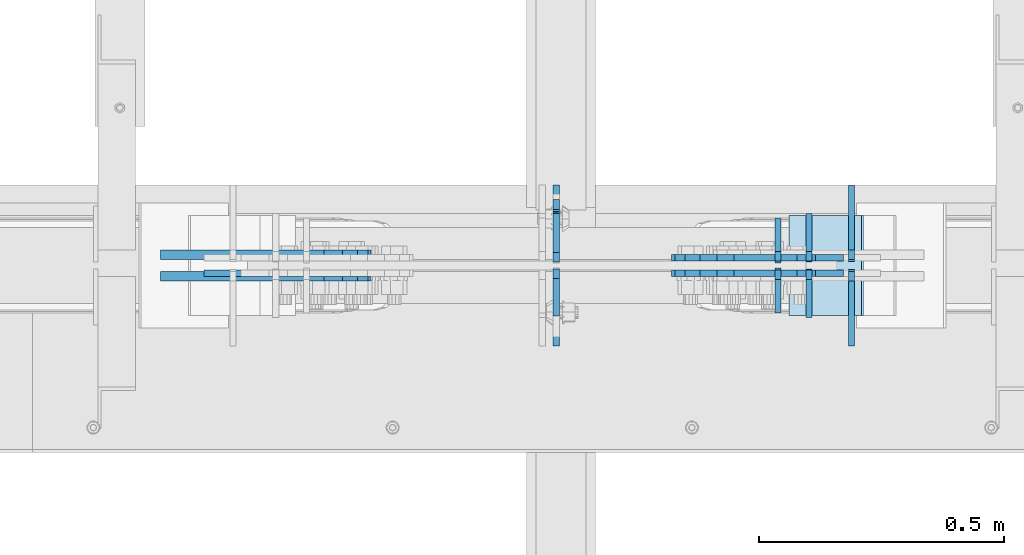
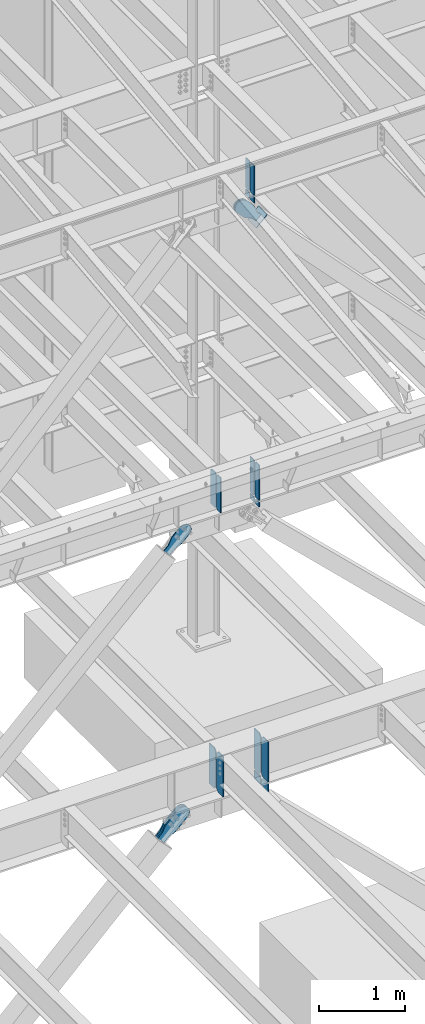
# One storey, part 1039 of 1179: 22 plates, 9 elements without a shape of their own.
"""IFC2X3 building model written with IfcOpenShell, lengths in millimetres."""

from ifc_helpers import new_model, si_unit, frame, origin_with_axes, place, context, subcontext, project, spatial, faceted_brep, material, type_object, element, aggregate, save


model = new_model("IFC2X3")

# Units and contexts
model_context = context("Model", 3, precision=1e-05, world=origin_with_axes())
body_context = subcontext(model_context, "Body", "Model", "MODEL_VIEW")
ifc_project = project(units=[si_unit("LENGTHUNIT", "METRE", prefix="MILLI"), si_unit("AREAUNIT", "SQUARE_METRE"), si_unit("VOLUMEUNIT", "CUBIC_METRE"), si_unit("MASSUNIT", "GRAM", prefix="KILO"), si_unit("TIMEUNIT", "SECOND"), si_unit("PLANEANGLEUNIT", "RADIAN"), si_unit("SOLIDANGLEUNIT", "STERADIAN"), si_unit("THERMODYNAMICTEMPERATUREUNIT", "DEGREE_CELSIUS"), si_unit("LUMINOUSINTENSITYUNIT", "LUMEN")], contexts=[model_context])

# Site, building, storey
site_placement = place(None, origin_with_axes())
site = spatial("IfcSite", under=ifc_project, at=site_placement, CompositionType="ELEMENT")
building_placement = place(site_placement, origin_with_axes())
building = spatial("IfcBuilding", under=site, at=building_placement, Name="Undefined", CompositionType="ELEMENT")
storey_placement = place(building_placement, origin_with_axes())
storey = spatial("IfcBuildingStorey", under=building, at=storey_placement, Name="Undefined", CompositionType="ELEMENT", Elevation=0.0)

# Assembly, plates
assembly_1_placement = place(storey_placement, origin_with_axes())
assembly_1 = element("IfcElementAssembly", 1, at=assembly_1_placement, inside=storey, Name="BEAM", AssemblyPlace="NOTDEFINED", PredefinedType="RIGID_FRAME")
ifc_material_1 = material(Name="STEEL/A572-GR.50")
plate_type_1 = type_object("IfcPlateType", PredefinedType="NOTDEFINED")
plate_1_placement = place(assembly_1_placement, frame((12398.375, 27043.85625, 7489.825), z_axis=(0.0, 0.0, 1.0), x_axis=(0.0, -1.0, 0.0)))
plate_1 = element("IfcPlate", 2, at=plate_1_placement, type_object=plate_type_1, material=ifc_material_1, Name="PLATE", context=body_context, shape_type="Brep", body=[
    faceted_brep([(0.0, -6.35000000000036, 19.0499999999993), (0.0, -6.350000000195, 479.425000761541), (0.0, 6.34999999980209, 479.425000761548), (0.0, 6.35000000000036, 19.0499999999993), (19.0499992370605, -6.35000000019863, 498.474999998592), (19.0499992370605, 6.34999999979118, 498.474999998596), (95.25, -6.349999999793, 498.474999998598), (95.25, 6.35000000020045, 498.474999998592), (95.25, -6.34999999999309, 1.81898940354586e-12), (95.25, 6.34999999999854, -1.81898940354586e-12), (19.0500000000002, -6.35000000000036, 0.0), (19.0500000000002, 6.35000000000036, 0.0)], [[[0, 1, 2, 3]], [[1, 4, 5, 2]], [[4, 6, 7, 5]], [[6, 8, 9, 7]], [[8, 10, 11, 9]], [[3, 11, 10, 0]], [[5, 7, 9, 11, 3, 2]], [[10, 8, 6, 4, 1, 0]]]),
])
plate_type_2 = type_object("IfcPlateType", PredefinedType="NOTDEFINED")
plate_2_placement = place(assembly_1_placement, frame((12912.8965081216, 27058.14375, 7489.825), z_axis=(0.0, 1.0, 0.0), x_axis=(0.0, 0.0, 1.0)))
plate_2 = element("IfcPlate", 3, at=plate_2_placement, type_object=plate_type_2, material=ifc_material_1, Name="PLATE", context=body_context, shape_type="Brep", body=[
    faceted_brep([(0.0, -6.34999999998763, 17.4624996185248), (0.0, -6.35000000000036, 99.21875), (0.0, 6.35000000000036, 99.21875), (0.0, 6.35000000000582, 17.4624996185175), (498.475, -6.35000000000036, 99.21875), (498.475, 6.35000000000036, 99.21875), (498.474999999775, -6.34999999979482, 17.4624996185303), (498.474999999769, 6.35000000019681, 17.4624996185303), (481.012500381255, -6.34999999980209, 0.0), (481.01250038125, 6.35000000019136, 0.0), (17.4624996185303, -6.34999999999309, 1.81898940354586e-12), (17.4624996185303, 6.34999999999854, -1.81898940354586e-12)], [[[0, 1, 2, 3]], [[1, 4, 5, 2]], [[4, 6, 7, 5]], [[6, 8, 9, 7]], [[8, 10, 11, 9]], [[10, 0, 3, 11]], [[5, 7, 9, 11, 3, 2]], [[10, 8, 6, 4, 1, 0]]]),
])
plate_3_placement = place(assembly_1_placement, frame((12912.8965081216, 27043.85625, 7489.825), z_axis=(0.0, -1.0, 0.0), x_axis=(0.0, 0.0, 1.0)))
plate_3 = element("IfcPlate", 4, at=plate_3_placement, type_object=plate_type_2, material=ifc_material_1, Name="PLATE", context=body_context, shape_type="Brep", body=[
    faceted_brep([(0.0, -6.34999999998763, 17.4624996185248), (0.0, -6.35000000000036, 99.21875), (0.0, 6.35000000000036, 99.21875), (0.0, 6.35000000000582, 17.4624996185175), (498.475, -6.35000000000036, 99.21875), (498.475, 6.35000000000036, 99.21875), (498.474999999775, -6.34999999979482, 17.4624996185303), (498.474999999769, 6.35000000019681, 17.4624996185303), (481.012500381255, -6.34999999980209, 0.0), (481.01250038125, 6.35000000019136, 0.0), (17.4624996185303, -6.34999999999309, 1.81898940354586e-12), (17.4624996185303, 6.34999999999854, -1.81898940354586e-12)], [[[0, 1, 2, 3]], [[1, 4, 5, 2]], [[4, 6, 7, 5]], [[6, 8, 9, 7]], [[8, 10, 11, 9]], [[10, 0, 3, 11]], [[5, 7, 9, 11, 3, 2]], [[10, 8, 6, 4, 1, 0]]]),
])

# Assembly, plate
assembly_2_placement = place(storey_placement, origin_with_axes())
assembly_2 = element("IfcElementAssembly", 5, at=assembly_2_placement, inside=storey, AssemblyPlace="NOTDEFINED", PredefinedType="RIGID_FRAME")
ifc_material_2 = material(Name="STEEL/A36")
plate_type_3 = type_object("IfcPlateType", PredefinedType="NOTDEFINED")
plate_4_placement = place(assembly_2_placement, frame((12926.5168524758, 27066.875, 11517.4881055865), z_axis=(-0.724386095169384, 0.0, -0.689394506161205), x_axis=(0.689394506161205, 0.0, -0.724386095169384)))
plate_4 = element("IfcPlate", 6, at=plate_4_placement, type_object=plate_type_3, material=ifc_material_2, context=body_context, shape_type="Brep", body=[
    faceted_brep([(0.0, -6.34999999999854, 0.0), (-101.600000000211, -6.34999999999854, -44.6881937825565), (-101.600000000211, 6.34999999999854, -44.6881937825565), (0.0, 6.34999999999854, 0.0), (-246.684985848258, -6.34999999999854, -44.6881937827675), (-246.684985848258, 6.34999999999854, -44.6881937827675), (-281.313054102191, -6.34999999999854, -37.800242748639), (-281.313054102191, 6.34999999999854, -37.800242748639), (-310.669312868691, -6.34999999999854, -18.1850177516608), (-310.669312868691, 6.34999999999854, -18.1850177516608), (-330.284537865713, -6.34999999999854, 11.1712410148393), (-330.284537865713, 6.34999999999854, 11.1712410148393), (-337.172488899912, -6.34999999999854, 45.7993031647638), (-337.172488899912, 6.34999999999854, 45.7993031647638), (-330.284537865768, -6.34999999999854, 80.4273714187839), (-330.284537865768, 6.34999999999854, 80.4273714187839), (-310.669312868773, -6.34999999999854, 109.783630185371), (-310.669312868773, 6.34999999999854, 109.783630185371), (-281.313054102271, -6.34999999999854, 129.398855182466), (-281.313054102271, 6.34999999999854, 129.398855182466), (-246.684988899762, -6.34999999999854, 136.286806216707), (-246.684988899762, 6.34999999999854, 136.286806216707), (-101.600000000377, -6.34999999999854, 136.286806216911), (-101.600000000377, 6.34999999999854, 136.286806216911), (-8.18545231595635e-11, -6.34999999999854, 91.5986124346418), (-8.18545231595635e-11, 6.34999999999854, 91.5986124346418), (82.5500000001266, -6.34999999999854, 91.5986124347546), (82.5500000001266, 6.34999999999854, 91.5986124347546), (82.550000000203, -6.34999999999854, 1.2732925824821e-10), (82.550000000203, 6.34999999999854, 1.2732925824821e-10)], [[[0, 1, 2, 3]], [[1, 4, 5, 2]], [[4, 6, 7, 5]], [[6, 8, 9, 7]], [[8, 10, 11, 9]], [[10, 12, 13, 11]], [[12, 14, 15, 13]], [[14, 16, 17, 15]], [[16, 18, 19, 17]], [[18, 20, 21, 19]], [[20, 22, 23, 21]], [[22, 24, 25, 23]], [[24, 26, 27, 25]], [[26, 28, 29, 27]], [[28, 0, 3, 29]], [[5, 7, 9, 11, 13, 15, 17, 19, 21, 23, 25, 27, 29, 3, 2]], [[28, 26, 24, 22, 20, 18, 16, 14, 12, 10, 8, 6, 4, 1, 0]]]),
])
aggregate(assembly_2, [plate_4])

assembly_3_placement = place(storey_placement, origin_with_axes())
assembly_3 = element("IfcElementAssembly", 7, at=assembly_3_placement, inside=storey, AssemblyPlace="NOTDEFINED", PredefinedType="RIGID_FRAME")
plate_5_placement = place(assembly_3_placement, frame((12926.5168524758, 27035.125, 11517.4881055865), z_axis=(-0.724386095169384, 0.0, -0.689394506161205), x_axis=(0.689394506161205, 0.0, -0.724386095169384)))
plate_5 = element("IfcPlate", 8, at=plate_5_placement, type_object=plate_type_3, material=ifc_material_2, context=body_context, shape_type="Brep", body=[
    faceted_brep([(0.0, -6.34999999999854, 0.0), (-101.600000000211, -6.34999999999854, -44.6881937825565), (-101.600000000211, 6.34999999999854, -44.6881937825565), (0.0, 6.34999999999854, 0.0), (-246.684985848258, -6.34999999999854, -44.6881937827675), (-246.684985848258, 6.34999999999854, -44.6881937827675), (-281.313054102191, -6.34999999999854, -37.800242748639), (-281.313054102191, 6.34999999999854, -37.800242748639), (-310.669312868691, -6.34999999999854, -18.1850177516608), (-310.669312868691, 6.34999999999854, -18.1850177516608), (-330.284537865713, -6.34999999999854, 11.1712410148393), (-330.284537865713, 6.34999999999854, 11.1712410148393), (-337.172488899912, -6.34999999999854, 45.7993031647638), (-337.172488899912, 6.34999999999854, 45.7993031647638), (-330.284537865768, -6.34999999999854, 80.4273714187839), (-330.284537865768, 6.34999999999854, 80.4273714187839), (-310.669312868773, -6.34999999999854, 109.783630185371), (-310.669312868773, 6.34999999999854, 109.783630185371), (-281.313054102271, -6.34999999999854, 129.398855182466), (-281.313054102271, 6.34999999999854, 129.398855182466), (-246.684988899762, -6.34999999999854, 136.286806216707), (-246.684988899762, 6.34999999999854, 136.286806216707), (-101.600000000377, -6.34999999999854, 136.286806216911), (-101.600000000377, 6.34999999999854, 136.286806216911), (-8.18545231595635e-11, -6.34999999999854, 91.5986124346418), (-8.18545231595635e-11, 6.34999999999854, 91.5986124346418), (82.5500000001266, -6.34999999999854, 91.5986124347546), (82.5500000001266, 6.34999999999854, 91.5986124347546), (82.550000000203, -6.34999999999854, 1.2732925824821e-10), (82.550000000203, 6.34999999999854, 1.2732925824821e-10)], [[[0, 1, 2, 3]], [[1, 4, 5, 2]], [[4, 6, 7, 5]], [[6, 8, 9, 7]], [[8, 10, 11, 9]], [[10, 12, 13, 11]], [[12, 14, 15, 13]], [[14, 16, 17, 15]], [[16, 18, 19, 17]], [[18, 20, 21, 19]], [[20, 22, 23, 21]], [[22, 24, 25, 23]], [[24, 26, 27, 25]], [[26, 28, 29, 27]], [[28, 0, 3, 29]], [[5, 7, 9, 11, 13, 15, 17, 19, 21, 23, 25, 27, 29, 3, 2]], [[28, 26, 24, 22, 20, 18, 16, 14, 12, 10, 8, 6, 4, 1, 0]]]),
])
aggregate(assembly_3, [plate_5])

assembly_4_placement = place(storey_placement, origin_with_axes())
assembly_4 = element("IfcElementAssembly", 9, at=assembly_4_placement, inside=storey, Name="Plate", AssemblyPlace="NOTDEFINED", PredefinedType="RIGID_FRAME")
plate_type_4 = type_object("IfcPlateType", PredefinedType="NOTDEFINED")
plate_6_placement = place(assembly_4_placement, frame((12874.4635335336, 27152.6, 11358.3736873647), z_axis=(0.724386095169386, 0.0, 0.689394506161204), x_axis=(0.0, -1.0, 0.0)))
plate_6 = element("IfcPlate", 10, at=plate_6_placement, type_object=plate_type_4, material=ifc_material_2, Name="Plate", context=body_context, shape_type="Brep", body=[
    faceted_brep([(0.0, -3.17500000000109, 0.0), (0.0, -3.17500000000291, 203.200000000368), (0.0, 3.17499999998836, 203.200000000361), (0.0, 3.17500000000109, 7.27595761418343e-12), (203.199999999997, -3.17500000000291, 203.200000000368), (203.199999999997, 3.17499999998836, 203.200000000361), (203.199999999997, -3.17499999999927, 3.63797880709171e-12), (203.199999999997, 3.17499999999382, -3.63797880709171e-12)], [[[0, 1, 2, 3]], [[1, 4, 5, 2]], [[4, 6, 7, 5]], [[6, 0, 3, 7]], [[5, 7, 3, 2]], [[6, 4, 1, 0]]]),
])
aggregate(assembly_4, [plate_6])

# Assembly, plates
assembly_5_placement = place(storey_placement, origin_with_axes())
assembly_5 = element("IfcElementAssembly", 11, at=assembly_5_placement, inside=storey, Name="BEAM", AssemblyPlace="NOTDEFINED", PredefinedType="RIGID_FRAME")
plate_type_5 = type_object("IfcPlateType", PredefinedType="NOTDEFINED")
plate_7_placement = place(assembly_5_placement, frame((12850.0952836325, 27056.5562499701, 11823.3031250357), z_axis=(0.0, 1.0, 0.0), x_axis=(0.0, 0.0, 1.0)))
plate_7 = element("IfcPlate", 12, at=plate_7_placement, type_object=plate_type_5, material=ifc_material_1, Name="PLATE", context=body_context, shape_type="Brep", body=[
    faceted_brep([(0.0, -6.34999999998763, 17.4624996185248), (0.0, -6.35000000000036, 91.28125), (0.0, 6.35000000000036, 91.28125), (0.0, 6.35000000000582, 17.4624996185175), (425.450000000001, -6.35000000000036, 91.28125), (425.450000000001, 6.35000000000036, 91.28125), (425.450000000001, -6.35000000000036, 17.4624996185303), (425.450000000001, 6.35000000000036, 17.4624996185303), (407.98750038147, -6.35000000000036, 0.0), (407.98750038147, 6.35000000000036, 0.0), (17.4624996185303, -6.34999999999309, 1.81898940354586e-12), (17.4624996185303, 6.34999999999854, -1.81898940354586e-12)], [[[0, 1, 2, 3]], [[1, 4, 5, 2]], [[4, 6, 7, 5]], [[6, 8, 9, 7]], [[8, 10, 11, 9]], [[10, 0, 3, 11]], [[5, 7, 9, 11, 3, 2]], [[10, 8, 6, 4, 1, 0]]]),
])
plate_8_placement = place(assembly_5_placement, frame((12850.0952836325, 27045.4437499701, 11823.3031250357), z_axis=(0.0, -1.0, 0.0), x_axis=(0.0, 0.0, 1.0)))
plate_8 = element("IfcPlate", 13, at=plate_8_placement, type_object=plate_type_5, material=ifc_material_1, Name="PLATE", context=body_context, shape_type="Brep", body=[
    faceted_brep([(0.0, -6.34999999998763, 17.4624996185248), (0.0, -6.35000000000036, 91.28125), (0.0, 6.35000000000036, 91.28125), (0.0, 6.35000000000582, 17.4624996185175), (425.450000000001, -6.35000000000036, 91.28125), (425.450000000001, 6.35000000000036, 91.28125), (425.450000000001, -6.35000000000036, 17.4624996185303), (425.450000000001, 6.35000000000036, 17.4624996185303), (407.98750038147, -6.35000000000036, 0.0), (407.98750038147, 6.35000000000036, 0.0), (17.4624996185303, -6.34999999999309, 1.81898940354586e-12), (17.4624996185303, 6.34999999999854, -1.81898940354586e-12)], [[[0, 1, 2, 3]], [[1, 4, 5, 2]], [[4, 6, 7, 5]], [[6, 8, 9, 7]], [[8, 10, 11, 9]], [[10, 0, 3, 11]], [[5, 7, 9, 11, 3, 2]], [[10, 8, 6, 4, 1, 0]]]),
])
plate_type_6 = type_object("IfcPlateType", PredefinedType="NOTDEFINED")
plate_9_placement = place(assembly_5_placement, frame((12850.0952836325, 27060.5249999701, 11802.6656250357), z_axis=(0.0, 1.0, 0.0), x_axis=(0.0, 0.0, -1.0)))
plate_9 = element("IfcPlate", 14, at=plate_9_placement, type_object=plate_type_6, material=ifc_material_1, Name="PLATE", context=body_context, shape_type="Brep", body=[
    faceted_brep([(0.0, 6.35000000000036, 19.0499999999993), (19.0500000000002, 6.35000000000036, 0.0), (19.0500000000002, -6.35000000000036, 0.0), (0.0, -6.35000000000036, 19.0499999999993), (0.0, -6.35000000000036, 87.3125), (0.0, 6.35000000000036, 87.3125), (87.061476451885, -6.35000000000036, 87.3125), (87.061476451885, 6.35000000000036, 87.3125), (87.061476451885, -6.35000000000036, 0.0), (87.061476451885, 6.35000000000036, 0.0)], [[[0, 1, 2, 3]], [[4, 5, 0, 3]], [[4, 6, 7, 5]], [[6, 8, 9, 7]], [[9, 8, 2, 1]], [[5, 7, 9, 1, 0]], [[8, 6, 4, 3, 2]]]),
])
plate_10_placement = place(assembly_5_placement, frame((12850.0952836325, 27041.4749999701, 11802.6656250357), z_axis=(0.0, -1.0, 0.0), x_axis=(0.0, 0.0, -1.0)))
plate_10 = element("IfcPlate", 15, at=plate_10_placement, type_object=plate_type_6, material=ifc_material_1, Name="PLATE", context=body_context, shape_type="Brep", body=[
    faceted_brep([(0.0, 6.35000000000036, 19.0499999999993), (19.0500000000002, 6.35000000000036, 0.0), (19.0500000000002, -6.35000000000036, 0.0), (0.0, -6.35000000000036, 19.0499999999993), (0.0, -6.35000000000036, 87.3125), (0.0, 6.35000000000036, 87.3125), (87.061476451885, -6.35000000000036, 87.3125), (87.061476451885, 6.35000000000036, 87.3125), (87.061476451885, -6.35000000000036, 0.0), (87.061476451885, 6.35000000000036, 0.0)], [[[0, 1, 2, 3]], [[4, 5, 0, 3]], [[4, 6, 7, 5]], [[6, 8, 9, 7]], [[9, 8, 2, 1]], [[5, 7, 9, 1, 0]], [[8, 6, 4, 3, 2]]]),
])
aggregate(assembly_5, [plate_7, plate_8, plate_9, plate_10])

# Plate
plate_type_7 = type_object("IfcPlateType", PredefinedType="NOTDEFINED")
plate_11_placement = place(assembly_1_placement, frame((12912.8965081217, 27060.525, 7464.42499999973), z_axis=(0.0, 1.0, 0.0), x_axis=(0.0, 0.0, -1.0)))
plate_11 = element("IfcPlate", 16, at=plate_11_placement, type_object=plate_type_7, material=ifc_material_1, Name="PLATE", context=body_context, shape_type="Brep", body=[
    faceted_brep([(0.0, 6.35000000000036, 19.0499999999993), (19.0500000000002, 6.35000000000036, 0.0), (19.0500000000002, -6.35000000000036, 0.0), (0.0, -6.35000000000036, 19.0499999999993), (0.0, -6.35000000000036, 96.8374999999978), (0.0, 6.35000000000036, 96.8374999999978), (66.4559488542145, -6.35000000000036, 96.8374999999978), (66.4559488542145, 6.35000000000036, 96.8374999999978), (66.4559488542145, -6.35000000000036, 0.0), (66.4559488542145, 6.35000000000036, 0.0)], [[[0, 1, 2, 3]], [[4, 5, 0, 3]], [[4, 6, 7, 5]], [[6, 8, 9, 7]], [[9, 8, 2, 1]], [[5, 7, 9, 1, 0]], [[8, 6, 4, 3, 2]]]),
])

plate_12_placement = place(assembly_1_placement, frame((12912.8965081217, 27041.475, 7464.42499999973), z_axis=(0.0, -1.0, 0.0), x_axis=(0.0, 0.0, -1.0)))
plate_12 = element("IfcPlate", 17, at=plate_12_placement, type_object=plate_type_7, material=ifc_material_1, Name="PLATE", context=body_context, shape_type="Brep", body=[
    faceted_brep([(0.0, 6.35000000000036, 19.0499999999993), (19.0500000000002, 6.35000000000036, 0.0), (19.0500000000002, -6.35000000000036, 0.0), (0.0, -6.35000000000036, 19.0499999999993), (0.0, -6.35000000000036, 96.8374999999978), (0.0, 6.35000000000036, 96.8374999999978), (66.4559488542145, -6.35000000000036, 96.8374999999978), (66.4559488542145, 6.35000000000036, 96.8374999999978), (66.4559488542145, -6.35000000000036, 0.0), (66.4559488542145, 6.35000000000036, 0.0)], [[[0, 1, 2, 3]], [[4, 5, 0, 3]], [[4, 6, 7, 5]], [[6, 8, 9, 7]], [[9, 8, 2, 1]], [[5, 7, 9, 1, 0]], [[8, 6, 4, 3, 2]]]),
])

plate_type_8 = type_object("IfcPlateType", PredefinedType="NOTDEFINED")
plate_13_placement = place(assembly_1_placement, frame((12398.375, 27058.14375, 7489.825), z_axis=(0.0, 0.0, 1.0), x_axis=(0.0, 1.0, 0.0)))
plate_13 = element("IfcPlate", 18, at=plate_13_placement, type_object=plate_type_8, material=ifc_material_1, Name="PLATE", context=body_context, shape_type="Brep", body=[
    faceted_brep([(99.21875, -6.35000000020227, 498.474999998592), (99.2187500000146, -6.35000000000036, 492.124999809268), (99.2187500000146, 6.35000000000036, 492.124999809268), (99.21875, 6.34999999978754, 498.474999998596), (100.185479922602, -6.35000000000036, 487.264920291223), (100.185479922602, 6.35000000000036, 487.264920291223), (102.93849382308, -6.35000000000036, 483.144743823069), (102.93849382308, 6.35000000000036, 483.144743823069), (107.058670291233, -6.35000000000036, 480.39172992259), (107.058670291233, 6.35000000000036, 480.39172992259), (111.91874980928, -6.35000000000036, 479.425000000003), (111.91874980928, 6.35000000000036, 479.425000000003), (127.000007629409, -6.35000000000036, 479.425000000003), (127.000004683807, 6.35000000000036, 479.425000000003), (0.0, -6.350000000195, 479.425000761541), (19.0499992370605, -6.35000000019863, 498.474999998592), (19.0499992370605, 6.34999999979118, 498.474999998596), (0.0, 6.34999999980209, 479.425000761548), (0.0, -6.35000000000036, 19.0499999999993), (0.0, 6.35000000000036, 19.0499999999993), (19.0500000000002, 6.35000000000036, 0.0), (19.0500000000002, -6.35000000000036, 0.0), (127.000004873051, -6.34999999999854, 0.0), (127.000004873051, 6.34999999999854, 0.0)], [[[0, 1, 2, 3]], [[4, 5, 2, 1]], [[6, 7, 5, 4]], [[8, 9, 7, 6]], [[10, 11, 9, 8]], [[12, 13, 11, 10]], [[14, 15, 16, 17]], [[18, 14, 17, 19]], [[19, 20, 21, 18]], [[22, 21, 20, 23]], [[8, 6, 4, 1, 0, 15, 14, 18, 21, 22, 12, 10]], [[15, 0, 3, 16]], [[23, 20, 19, 17, 16, 3, 2, 5, 7, 9, 11, 13]], [[22, 23, 13, 12]]]),
])

aggregate(assembly_1, [plate_2, plate_3, plate_11, plate_12, plate_1, plate_13])

# Assembly, plates
assembly_6_placement = place(storey_placement, origin_with_axes())
assembly_6 = element("IfcElementAssembly", 19, at=assembly_6_placement, inside=storey, Name="BEAM", AssemblyPlace="NOTDEFINED", PredefinedType="RIGID_FRAME")
plate_type_9 = type_object("IfcPlateType", PredefinedType="NOTDEFINED")
plate_14_placement = place(assembly_6_placement, frame((12999.6406251867, 26890.6625, 3505.2), z_axis=(0.0, 0.0, 1.0), x_axis=(0.0, 1.0, 0.0)))
plate_14 = element("IfcPlate", 20, at=plate_14_placement, type_object=plate_type_9, material=ifc_material_1, Name="PLATE", context=body_context, shape_type="Brep", body=[
    faceted_brep([(0.0, -6.34999999999854, 0.0), (0.0, -6.35000000000036, 571.5), (0.0, 6.35000000000036, 571.5), (0.0, 6.34999999999854, 0.0), (117.475000762941, -6.35000000000036, 571.5), (117.475000762941, 6.35000000000036, 571.5), (152.400000000001, -6.35000000000036, 536.575000762939), (152.400000000001, 6.35000000000036, 536.575000762939), (152.400000000001, -6.35000000000036, 34.9249992370605), (152.400000000001, 6.35000000000036, 34.9249992370605), (117.475000762941, -6.35000000000036, 0.0), (117.475000762941, 6.35000000000036, 0.0)], [[[0, 1, 2, 3]], [[1, 4, 5, 2]], [[4, 6, 7, 5]], [[6, 8, 9, 7]], [[8, 10, 11, 9]], [[10, 0, 3, 11]], [[5, 7, 9, 11, 3, 2]], [[10, 8, 6, 4, 1, 0]]]),
])
plate_15_placement = place(assembly_6_placement, frame((12999.6406251867, 27058.9375, 3505.2), z_axis=(0.0, 0.0, 1.0), x_axis=(0.0, 1.0, 0.0)))
plate_15 = element("IfcPlate", 21, at=plate_15_placement, type_object=plate_type_9, material=ifc_material_1, Name="PLATE", context=body_context, shape_type="Brep", body=[
    faceted_brep([(0.0, -6.35000000000036, 34.9249992370605), (0.0, -6.35000000000036, 536.575000762939), (0.0, 6.35000000000036, 536.575000762939), (0.0, 6.35000000000036, 34.9249992370605), (34.9249992370605, -6.35000000000036, 571.5), (34.9249992370605, 6.35000000000036, 571.5), (152.400000000001, -6.35000000000036, 571.5), (152.400000000001, 6.35000000000036, 571.5), (152.400000000001, -6.35000000000036, 0.0), (152.400000000001, 6.35000000000036, 0.0), (34.9249992370605, -6.35000000000036, 0.0), (34.9249992370605, 6.35000000000036, 0.0)], [[[0, 1, 2, 3]], [[1, 4, 5, 2]], [[4, 6, 7, 5]], [[6, 8, 9, 7]], [[8, 10, 11, 9]], [[10, 0, 3, 11]], [[5, 7, 9, 11, 3, 2]], [[10, 8, 6, 4, 1, 0]]]),
])
plate_type_10 = type_object("IfcPlateType", PredefinedType="NOTDEFINED")
plate_16_placement = place(assembly_6_placement, frame((12999.6566185934, 27063.7, 3479.8), z_axis=(0.0, 1.0, 0.0), x_axis=(0.0, 0.0, -1.0)))
plate_16 = element("IfcPlate", 22, at=plate_16_placement, type_object=plate_type_10, material=ifc_material_1, Name="PLATE", context=body_context, shape_type="Brep", body=[
    faceted_brep([(0.0, -6.35000000000036, 19.0499999999993), (0.0, -6.35000000000036, 150.8125), (0.0, 6.35000000000036, 150.8125), (0.0, 6.35000000000036, 19.0499999999993), (114.654452531247, -6.35000000000036, 150.8125), (114.654452531247, 6.35000000000036, 150.8125), (114.654452531247, -6.35000000000036, 0.0), (114.654452531247, 6.35000000000036, 0.0), (19.0500000000002, -6.35000000000036, 0.0), (19.0500000000002, 6.35000000000036, 0.0)], [[[0, 1, 2, 3]], [[1, 4, 5, 2]], [[4, 6, 7, 5]], [[6, 8, 9, 7]], [[3, 9, 8, 0]], [[5, 7, 9, 3, 2]], [[8, 6, 4, 1, 0]]]),
])
plate_17_placement = place(assembly_6_placement, frame((12999.6566185934, 27038.3, 3479.8), z_axis=(0.0, -1.0, 0.0), x_axis=(0.0, 0.0, -1.0)))
plate_17 = element("IfcPlate", 23, at=plate_17_placement, type_object=plate_type_10, material=ifc_material_1, Name="PLATE", context=body_context, shape_type="Brep", body=[
    faceted_brep([(0.0, -6.35000000000036, 19.0499999999993), (0.0, -6.35000000000036, 150.8125), (0.0, 6.35000000000036, 150.8125), (0.0, 6.35000000000036, 19.0499999999993), (114.654452531247, -6.35000000000036, 150.8125), (114.654452531247, 6.35000000000036, 150.8125), (114.654452531247, -6.35000000000036, 0.0), (114.654452531247, 6.35000000000036, 0.0), (19.0500000000002, -6.35000000000036, 0.0), (19.0500000000002, 6.35000000000036, 0.0)], [[[0, 1, 2, 3]], [[1, 4, 5, 2]], [[4, 6, 7, 5]], [[6, 8, 9, 7]], [[3, 9, 8, 0]], [[5, 7, 9, 3, 2]], [[8, 6, 4, 1, 0]]]),
])

# Assembly, plate
assembly_7_placement = place(storey_placement, origin_with_axes())
assembly_7 = element("IfcElementAssembly", 24, at=assembly_7_placement, inside=storey, AssemblyPlace="NOTDEFINED", PredefinedType="RIGID_FRAME")
plate_type_11 = type_object("IfcPlateType", PredefinedType="NOTDEFINED")
plate_18_placement = place(assembly_7_placement, frame((11758.7028563309, 27035.125, 7071.23633215706), z_axis=(-0.694497308871752, 0.0, 0.719495300867138), x_axis=(0.719495300867139, 0.0, 0.694497308871752)))
plate_18 = element("IfcPlate", 25, at=plate_18_placement, type_object=plate_type_11, material=ifc_material_2, context=body_context, shape_type="Brep", body=[
    faceted_brep([(0.0, -6.34999999999854, 0.0), (-4.35647962149233e-10, -6.34999999999854, 112.184930806416), (-4.35647962149233e-10, 6.34999999999854, 112.184930806416), (0.0, 6.34999999999854, 0.0), (82.5499999996491, -6.34999999999854, 112.184930806461), (82.5499999996491, 6.34999999999854, 112.184930806461), (184.149999999618, -6.34999999999854, 149.75496540347), (184.149999999618, 6.34999999999854, 149.75496540347), (327.919242323534, -6.34999999999854, 149.754965403559), (327.919242323534, 6.34999999999854, 149.754965403559), (363.762328723451, -6.34999999999854, 142.625332233587), (363.762328723451, 6.34999999999854, 142.625332233587), (394.148630137406, -6.34999999999854, 122.321854743475), (394.148630137406, 6.34999999999854, 122.321854743475), (414.452107627645, -6.34999999999854, 91.9355533295929), (414.452107627645, 6.34999999999854, 91.9355533295929), (421.581740797776, -6.34999999999854, 56.0924638777396), (421.581740797776, 6.34999999999854, 56.0924638777396), (414.452107627878, -6.34999999999854, 20.2493774776722), (414.452107627878, 6.34999999999854, 20.2493774776722), (394.14863013775, -6.34999999999854, -10.1369239363994), (394.14863013775, 6.34999999999854, -10.1369239363994), (363.762328723789, -6.34999999999854, -30.4404014266784), (363.762328723789, 6.34999999999854, -30.4404014266784), (327.919240798041, -6.34999999999854, -37.570034596738), (327.919240798041, 6.34999999999854, -37.570034596738), (184.150000000338, -6.34999999999854, -37.5700345968289), (184.150000000338, 6.34999999999854, -37.5700345968289), (82.550000000203, -6.34999999999854, 1.2732925824821e-10), (82.550000000203, 6.34999999999854, 1.2732925824821e-10)], [[[0, 1, 2, 3]], [[1, 4, 5, 2]], [[4, 6, 7, 5]], [[6, 8, 9, 7]], [[8, 10, 11, 9]], [[10, 12, 13, 11]], [[12, 14, 15, 13]], [[14, 16, 17, 15]], [[16, 18, 19, 17]], [[18, 20, 21, 19]], [[20, 22, 23, 21]], [[22, 24, 25, 23]], [[24, 26, 27, 25]], [[26, 28, 29, 27]], [[28, 0, 3, 29]], [[5, 7, 9, 11, 13, 15, 17, 19, 21, 23, 25, 27, 29, 3, 2]], [[28, 26, 24, 22, 20, 18, 16, 14, 12, 10, 8, 6, 4, 1, 0]]]),
])
aggregate(assembly_7, [plate_18])

assembly_8_placement = place(storey_placement, origin_with_axes())
assembly_8 = element("IfcElementAssembly", 26, at=assembly_8_placement, inside=storey, AssemblyPlace="NOTDEFINED", PredefinedType="RIGID_FRAME")
plate_type_12 = type_object("IfcPlateType", PredefinedType="NOTDEFINED")
plate_19_placement = place(assembly_8_placement, frame((11681.2584675617, 27073.225, 3027.38828889636), z_axis=(-0.699860687134476, 0.0, 0.714279370137245), x_axis=(0.714279370137245, 0.0, 0.699860687134476)))
plate_19 = element("IfcPlate", 27, at=plate_19_placement, type_object=plate_type_12, material=ifc_material_2, context=body_context, shape_type="Brep", body=[
    faceted_brep([(0.0, -9.52499999999964, 0.0), (-5.72072167415172e-10, -9.52500000000146, 127.026455577978), (-5.72072167415172e-10, 9.52500000000146, 127.026455577978), (0.0, 9.52499999999964, 0.0), (82.5499999996218, -9.52500000000146, 127.02645557804), (82.5499999996218, 9.52500000000146, 127.02645557804), (184.149999999816, -9.52500000000146, 160.350727789162), (184.149999999816, 9.52500000000146, 160.350727789162), (402.829297671884, -9.52500000000146, 160.350727789319), (402.829297671884, 9.52500000000146, 160.350727789319), (439.887405137379, -9.52500000000146, 152.97941190279), (439.887405137379, 9.52500000000146, 152.97941190279), (471.303751673868, -9.52500000000146, 131.987680265722), (471.303751673868, 9.52500000000146, 131.987680265722), (492.295483311087, -9.52500000000146, 100.571333729322), (492.295483311087, 9.52500000000146, 100.571333729322), (499.666799197799, -9.52500000000146, 63.5132293155057), (499.666799197799, 9.52500000000146, 63.5132293155057), (492.295483311342, -9.52500000000146, 26.4551218498), (492.295483311342, 9.52500000000146, 26.4551218498), (471.303751674215, -9.52500000000146, -4.96122468687645), (471.303751674215, 9.52500000000146, -4.96122468687645), (439.887405137664, -9.52500000000146, -25.9529563241722), (439.887405137664, 9.52500000000146, -25.9529563241722), (402.829299197954, -9.52500000000146, -33.3242722108225), (402.829299197954, 9.52500000000146, -33.3242722108225), (184.150000000667, -9.52500000000146, -33.324272210979), (184.150000000667, 9.52500000000146, -33.324272210979), (82.5499999997119, -9.52500000000146, 1.81898940354586e-11), (82.5499999997119, 9.52500000000146, 1.81898940354586e-11)], [[[0, 1, 2, 3]], [[1, 4, 5, 2]], [[4, 6, 7, 5]], [[6, 8, 9, 7]], [[8, 10, 11, 9]], [[10, 12, 13, 11]], [[12, 14, 15, 13]], [[14, 16, 17, 15]], [[16, 18, 19, 17]], [[18, 20, 21, 19]], [[20, 22, 23, 21]], [[22, 24, 25, 23]], [[24, 26, 27, 25]], [[26, 28, 29, 27]], [[28, 0, 3, 29]], [[5, 7, 9, 11, 13, 15, 17, 19, 21, 23, 25, 27, 29, 3, 2]], [[28, 26, 24, 22, 20, 18, 16, 14, 12, 10, 8, 6, 4, 1, 0]]]),
])
aggregate(assembly_8, [plate_19])

assembly_9_placement = place(storey_placement, origin_with_axes())
assembly_9 = element("IfcElementAssembly", 28, at=assembly_9_placement, inside=storey, AssemblyPlace="NOTDEFINED", PredefinedType="RIGID_FRAME")
plate_20_placement = place(assembly_9_placement, frame((11681.2584675617, 27028.775, 3027.38828889636), z_axis=(-0.699860687134476, 0.0, 0.714279370137245), x_axis=(0.714279370137245, 0.0, 0.699860687134476)))
plate_20 = element("IfcPlate", 29, at=plate_20_placement, type_object=plate_type_12, material=ifc_material_2, context=body_context, shape_type="Brep", body=[
    faceted_brep([(0.0, -9.52499999999964, 0.0), (-5.72072167415172e-10, -9.52500000000146, 127.026455577978), (-5.72072167415172e-10, 9.52500000000146, 127.026455577978), (0.0, 9.52499999999964, 0.0), (82.5499999996218, -9.52500000000146, 127.02645557804), (82.5499999996218, 9.52500000000146, 127.02645557804), (184.149999999816, -9.52500000000146, 160.350727789162), (184.149999999816, 9.52500000000146, 160.350727789162), (402.829297671884, -9.52500000000146, 160.350727789319), (402.829297671884, 9.52500000000146, 160.350727789319), (439.887405137379, -9.52500000000146, 152.97941190279), (439.887405137379, 9.52500000000146, 152.97941190279), (471.303751673868, -9.52500000000146, 131.987680265722), (471.303751673868, 9.52500000000146, 131.987680265722), (492.295483311087, -9.52500000000146, 100.571333729322), (492.295483311087, 9.52500000000146, 100.571333729322), (499.666799197799, -9.52500000000146, 63.5132293155057), (499.666799197799, 9.52500000000146, 63.5132293155057), (492.295483311342, -9.52500000000146, 26.4551218498), (492.295483311342, 9.52500000000146, 26.4551218498), (471.303751674215, -9.52500000000146, -4.96122468687645), (471.303751674215, 9.52500000000146, -4.96122468687645), (439.887405137664, -9.52500000000146, -25.9529563241722), (439.887405137664, 9.52500000000146, -25.9529563241722), (402.829299197954, -9.52500000000146, -33.3242722108225), (402.829299197954, 9.52500000000146, -33.3242722108225), (184.150000000667, -9.52500000000146, -33.324272210979), (184.150000000667, 9.52500000000146, -33.324272210979), (82.5499999997119, -9.52500000000146, 1.81898940354586e-11), (82.5499999997119, 9.52500000000146, 1.81898940354586e-11)], [[[0, 1, 2, 3]], [[1, 4, 5, 2]], [[4, 6, 7, 5]], [[6, 8, 9, 7]], [[8, 10, 11, 9]], [[10, 12, 13, 11]], [[12, 14, 15, 13]], [[14, 16, 17, 15]], [[16, 18, 19, 17]], [[18, 20, 21, 19]], [[20, 22, 23, 21]], [[22, 24, 25, 23]], [[24, 26, 27, 25]], [[26, 28, 29, 27]], [[28, 0, 3, 29]], [[5, 7, 9, 11, 13, 15, 17, 19, 21, 23, 25, 27, 29, 3, 2]], [[28, 26, 24, 22, 20, 18, 16, 14, 12, 10, 8, 6, 4, 1, 0]]]),
])
aggregate(assembly_9, [plate_20])

# Plate
plate_type_13 = type_object("IfcPlateType", PredefinedType="NOTDEFINED")
plate_21_placement = place(assembly_6_placement, frame((12398.375, 27058.9375, 3505.2), z_axis=(0.0, 0.0, 1.0), x_axis=(0.0, 1.0, 0.0)))
plate_21 = element("IfcPlate", 30, at=plate_21_placement, type_object=plate_type_13, material=ifc_material_1, Name="PLATE", context=body_context, shape_type="Brep", body=[
    faceted_brep([(0.0, -6.35000000000036, 34.9249992370605), (0.0, -6.35000000000036, 536.575000762939), (0.0, 6.35000000000036, 536.575000762939), (0.0, 6.35000000000036, 34.9249992370605), (34.9249992370605, -6.35000000000036, 571.5), (34.9249992370605, 6.35000000000036, 571.5), (155.575000000001, -6.35000000000036, 571.5), (155.575000000001, 6.35000000000036, 571.5), (155.575000000001, -6.35000000000036, 0.0), (155.575000000001, 6.35000000000036, 0.0), (34.9249992370605, -6.35000000000036, 0.0), (34.9249992370605, 6.35000000000036, 0.0)], [[[0, 1, 2, 3]], [[1, 4, 5, 2]], [[4, 6, 7, 5]], [[6, 8, 9, 7]], [[8, 10, 11, 9]], [[10, 0, 3, 11]], [[5, 7, 9, 11, 3, 2]], [[10, 8, 6, 4, 1, 0]]]),
])

plate_22_placement = place(assembly_6_placement, frame((12398.3748828559, 27043.0625, 3505.2), z_axis=(0.0, 0.0, 1.0), x_axis=(0.0, -1.0, 0.0)))
plate_22 = element("IfcPlate", 31, at=plate_22_placement, type_object=plate_type_13, material=ifc_material_1, Name="PLATE", context=body_context, shape_type="Brep", body=[
    faceted_brep([(0.0, -6.35000000000036, 34.9249992370605), (0.0, -6.35000000000036, 536.575000762939), (0.0, 6.35000000000036, 536.575000762939), (0.0, 6.35000000000036, 34.9249992370605), (34.9249992370605, -6.35000000000036, 571.5), (34.9249992370605, 6.35000000000036, 571.5), (155.575000000001, -6.35000000000036, 571.5), (155.575000000001, 6.35000000000036, 571.5), (155.575000000001, -6.35000000000036, 0.0), (155.575000000001, 6.35000000000036, 0.0), (34.9249992370605, -6.35000000000036, 0.0), (34.9249992370605, 6.35000000000036, 0.0)], [[[0, 1, 2, 3]], [[1, 4, 5, 2]], [[4, 6, 7, 5]], [[6, 8, 9, 7]], [[8, 10, 11, 9]], [[10, 0, 3, 11]], [[5, 7, 9, 11, 3, 2]], [[10, 8, 6, 4, 1, 0]]]),
])

aggregate(assembly_6, [plate_14, plate_15, plate_16, plate_17, plate_21, plate_22])

save(model, "model.ifc")
